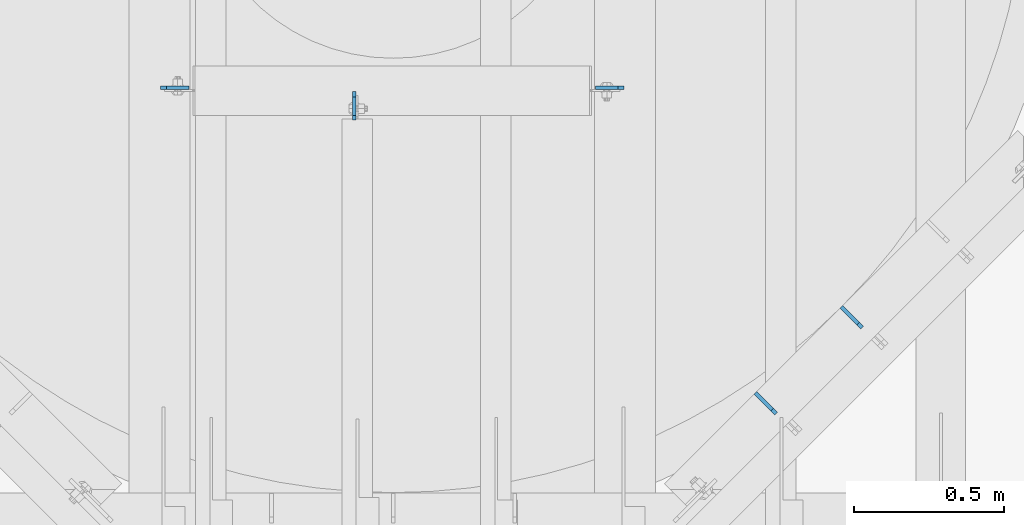
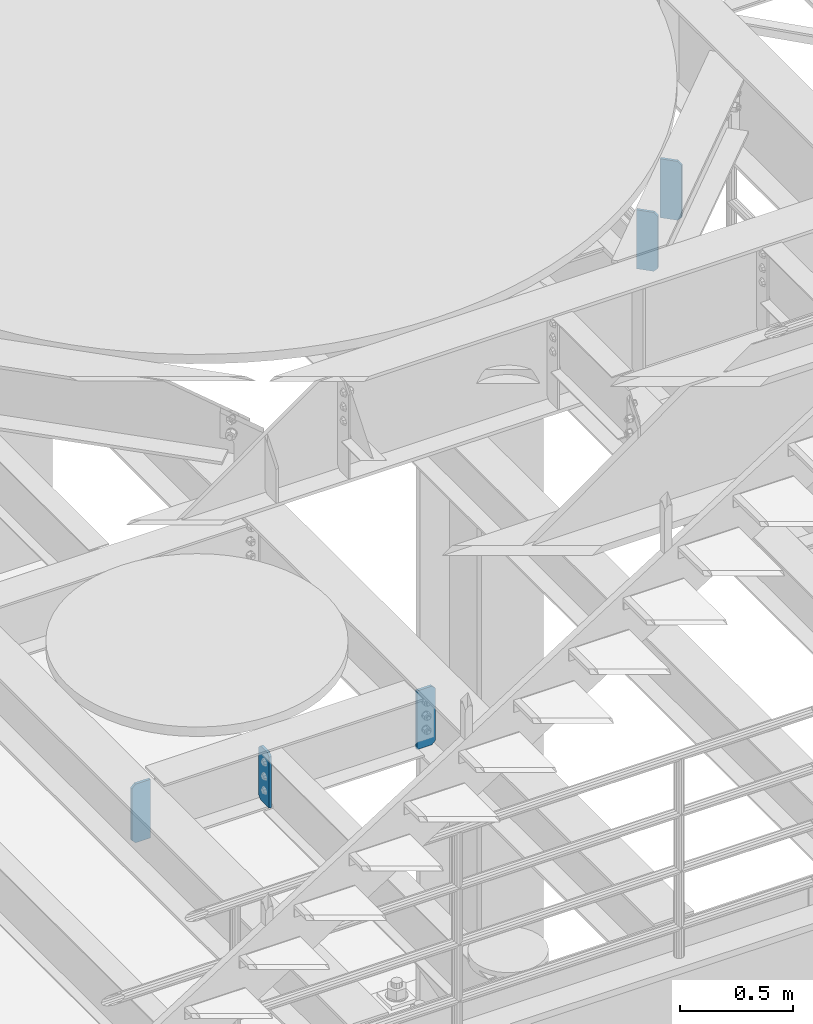
# One storey, part 1509 of 1876: 5 plates, 4 elements without a shape of their own.
"""IFC2X3 building model written with IfcOpenShell, lengths in millimetres."""

from ifc_helpers import new_model, si_unit, frame, origin_with_axes, place, context, subcontext, project, spatial, faceted_brep, material, type_object, element, aggregate, save


model = new_model("IFC2X3")

# Units and contexts
model_context = context("Model", 3, precision=1e-05, world=origin_with_axes())
body_context = subcontext(model_context, "Body", "Model", "MODEL_VIEW")
ifc_project = project(units=[si_unit("LENGTHUNIT", "METRE", prefix="MILLI"), si_unit("AREAUNIT", "SQUARE_METRE"), si_unit("VOLUMEUNIT", "CUBIC_METRE"), si_unit("MASSUNIT", "GRAM", prefix="KILO"), si_unit("TIMEUNIT", "SECOND"), si_unit("PLANEANGLEUNIT", "RADIAN"), si_unit("SOLIDANGLEUNIT", "STERADIAN"), si_unit("THERMODYNAMICTEMPERATUREUNIT", "DEGREE_CELSIUS"), si_unit("LUMINOUSINTENSITYUNIT", "LUMEN")], contexts=[model_context])

# Site, building, storey
site_placement = place(None, origin_with_axes())
site = spatial("IfcSite", under=ifc_project, at=site_placement, CompositionType="ELEMENT")
building_placement = place(site_placement, origin_with_axes())
building = spatial("IfcBuilding", under=site, at=building_placement, Name="Undefined", CompositionType="ELEMENT")
storey_placement = place(building_placement, origin_with_axes())
storey = spatial("IfcBuildingStorey", under=building, at=storey_placement, Name="Undefined", CompositionType="ELEMENT", Elevation=0.0)

# Assembly, plates
assembly_1_placement = place(storey_placement, origin_with_axes())
assembly_1 = element("IfcElementAssembly", 1, at=assembly_1_placement, inside=storey, Name="BEAM", AssemblyPlace="NOTDEFINED", PredefinedType="RIGID_FRAME")
ifc_material = material(Name="STEEL/A36")
plate_type_1 = type_object("IfcPlateType", PredefinedType="NOTDEFINED")
plate_1_placement = place(assembly_1_placement, frame((5698.70199439045, -3377.83472848824, 7820.025), z_axis=(0.0, 0.0, 1.0), x_axis=(-0.707106781186548, 0.707106781186547, 0.0)))
plate_1 = element("IfcPlate", 2, at=plate_1_placement, type_object=plate_type_1, material=ifc_material, Name="PLATE", context=body_context, shape_type="Brep", body=[
    faceted_brep([(0.0, -6.35000000000196, 19.0499992370605), (0.0, -6.35000000000196, 298.450000762939), (0.0, 6.35000000000105, 298.450000762939), (0.0, 6.35000000000105, 19.0499992370605), (19.0499992370642, -6.35000000000105, 317.5), (19.0499992370633, 6.35000000000105, 317.5), (98.425003051776, -6.34999999999832, 317.5), (98.425003051776, 6.35000000000423, 317.5), (98.425003051776, -6.34999999999832, 0.0), (98.425003051776, 6.35000000000423, 0.0), (19.0499992370642, -6.35000000000105, 0.0), (19.0499992370633, 6.35000000000105, 0.0)], [[[0, 1, 2, 3]], [[1, 4, 5, 2]], [[4, 6, 7, 5]], [[6, 8, 9, 7]], [[8, 10, 11, 9]], [[10, 0, 3, 11]], [[5, 7, 9, 11, 3, 2]], [[10, 8, 6, 4, 1, 0]]]),
])
plate_2_placement = place(assembly_1_placement, frame((5986.07024350311, -3090.46658585238, 7820.025), z_axis=(0.0, 0.0, 1.0), x_axis=(-0.707106781186548, 0.707106781186547, 0.0)))
plate_2 = element("IfcPlate", 3, at=plate_2_placement, type_object=plate_type_1, material=ifc_material, Name="PLATE", context=body_context, shape_type="Brep", body=[
    faceted_brep([(0.0, -6.35000000000196, 19.0499992370605), (0.0, -6.35000000000196, 298.450000762939), (0.0, 6.35000000000105, 298.450000762939), (0.0, 6.35000000000105, 19.0499992370605), (19.0499992370642, -6.35000000000105, 317.5), (19.0499992370633, 6.35000000000105, 317.5), (98.425003051776, -6.34999999999832, 317.5), (98.425003051776, 6.35000000000423, 317.5), (98.425003051776, -6.34999999999832, 0.0), (98.425003051776, 6.35000000000423, 0.0), (19.0499992370642, -6.35000000000105, 0.0), (19.0499992370633, 6.35000000000105, 0.0)], [[[0, 1, 2, 3]], [[1, 4, 5, 2]], [[4, 6, 7, 5]], [[6, 8, 9, 7]], [[8, 10, 11, 9]], [[10, 0, 3, 11]], [[5, 7, 9, 11, 3, 2]], [[10, 8, 6, 4, 1, 0]]]),
])
aggregate(assembly_1, [plate_1, plate_2])

# Assembly, plate
assembly_2_placement = place(storey_placement, origin_with_axes())
assembly_2 = element("IfcElementAssembly", 4, at=assembly_2_placement, inside=storey, Name="BEAM", AssemblyPlace="NOTDEFINED", PredefinedType="RIGID_FRAME")
plate_type_2 = type_object("IfcPlateType", PredefinedType="NOTDEFINED")
plate_3_placement = place(assembly_2_placement, frame((3642.51875, -2289.17499990463, 4799.0125), z_axis=(0.0, 0.0, 1.0), x_axis=(1.0, 0.0, 0.0)))
plate_3 = element("IfcPlate", 5, at=plate_3_placement, type_object=plate_type_2, material=ifc_material, Name="PLATE", context=body_context, shape_type="Brep", body=[
    faceted_brep([(0.0, -6.35000000000196, 19.0499992370605), (-9.09494701772928e-13, -6.34999999999764, 296.862506866455), (1.81898940354586e-12, 6.34999999999786, 296.862506866455), (0.0, 6.35000000000105, 19.0499992370605), (19.0499992370587, -6.34999999999604, 315.912506103516), (19.0499992370624, 6.34999999999945, 315.912506103516), (95.25, -6.35000000000036, 315.912506103516), (95.25, 6.35000000000036, 315.912506103516), (95.25, -6.35000000000036, 0.0), (95.25, 6.35000000000036, 0.0), (19.0499992370642, -6.35000000000105, 0.0), (19.0499992370633, 6.35000000000105, 0.0)], [[[0, 1, 2, 3]], [[1, 4, 5, 2]], [[4, 6, 7, 5]], [[6, 8, 9, 7]], [[8, 10, 11, 9]], [[10, 0, 3, 11]], [[5, 7, 9, 11, 3, 2]], [[10, 8, 6, 4, 1, 0]]]),
])
aggregate(assembly_2, [plate_3])

assembly_3_placement = place(storey_placement, origin_with_axes())
assembly_3 = element("IfcElementAssembly", 6, at=assembly_3_placement, inside=storey, Name="BEAM", AssemblyPlace="NOTDEFINED", PredefinedType="RIGID_FRAME")
plate_4_placement = place(assembly_3_placement, frame((5190.33125, -2289.17499990463, 4799.0125), z_axis=(0.0, 0.0, 1.0), x_axis=(-1.0, 0.0, 0.0)))
plate_4 = element("IfcPlate", 7, at=plate_4_placement, type_object=plate_type_2, material=ifc_material, Name="PLATE", context=body_context, shape_type="Brep", body=[
    faceted_brep([(0.0, -6.35000000000196, 19.0499992370605), (-9.09494701772928e-13, -6.34999999999764, 296.862506866455), (1.81898940354586e-12, 6.34999999999786, 296.862506866455), (0.0, 6.35000000000105, 19.0499992370605), (19.0499992370587, -6.34999999999604, 315.912506103516), (19.0499992370624, 6.34999999999945, 315.912506103516), (95.25, -6.35000000000036, 315.912506103516), (95.25, 6.35000000000036, 315.912506103516), (95.25, -6.35000000000036, 0.0), (95.25, 6.35000000000036, 0.0), (19.0499992370642, -6.35000000000105, 0.0), (19.0499992370633, 6.35000000000105, 0.0)], [[[0, 1, 2, 3]], [[1, 4, 5, 2]], [[4, 6, 7, 5]], [[6, 8, 9, 7]], [[8, 10, 11, 9]], [[10, 0, 3, 11]], [[5, 7, 9, 11, 3, 2]], [[10, 8, 6, 4, 1, 0]]]),
])
aggregate(assembly_3, [plate_4])

assembly_4_placement = place(storey_placement, origin_with_axes())
assembly_4 = element("IfcElementAssembly", 8, at=assembly_4_placement, inside=storey, Name="BEAM", AssemblyPlace="NOTDEFINED", PredefinedType="RIGID_FRAME")
plate_5_placement = place(assembly_4_placement, frame((4289.42499990463, -2301.875, 4829.175), z_axis=(0.0, 0.0, 1.0), x_axis=(0.0, -1.0, 0.0)))
plate_5 = element("IfcPlate", 9, at=plate_5_placement, type_object=plate_type_2, material=ifc_material, Name="PLATE", context=body_context, shape_type="Brep", body=[
    faceted_brep([(0.0, -6.35000000000036, 271.462512969971), (19.0499992370605, -6.35000000000036, 290.512512207031), (19.0499992370605, 6.35000000000036, 290.512512207031), (0.0, 6.35000000000036, 271.462512969971), (0.0, -6.35000000000196, 19.0499992370605), (0.0, 6.35000000000105, 19.0499992370605), (19.0499992370642, -6.35000000000105, 0.0), (19.0499992370633, 6.35000000000105, 0.0), (95.25, -6.35000000000036, 0.0), (95.25, 6.35000000000036, 0.0), (95.25, -6.35000000000036, 274.637511908913), (79.3749874887271, -6.35000000000036, 290.512512207031), (79.3749874887271, 6.35000000000036, 290.512512207031), (95.25, 6.35000000000036, 274.637511908913)], [[[0, 1, 2, 3]], [[4, 0, 3, 5]], [[6, 4, 5, 7]], [[8, 6, 7, 9]], [[1, 0, 4, 6, 8, 10, 11]], [[2, 1, 11, 12]], [[9, 7, 5, 3, 2, 12, 13]], [[8, 9, 13, 10]], [[12, 11, 10, 13]]]),
])
aggregate(assembly_4, [plate_5])

save(model, "model.ifc")
